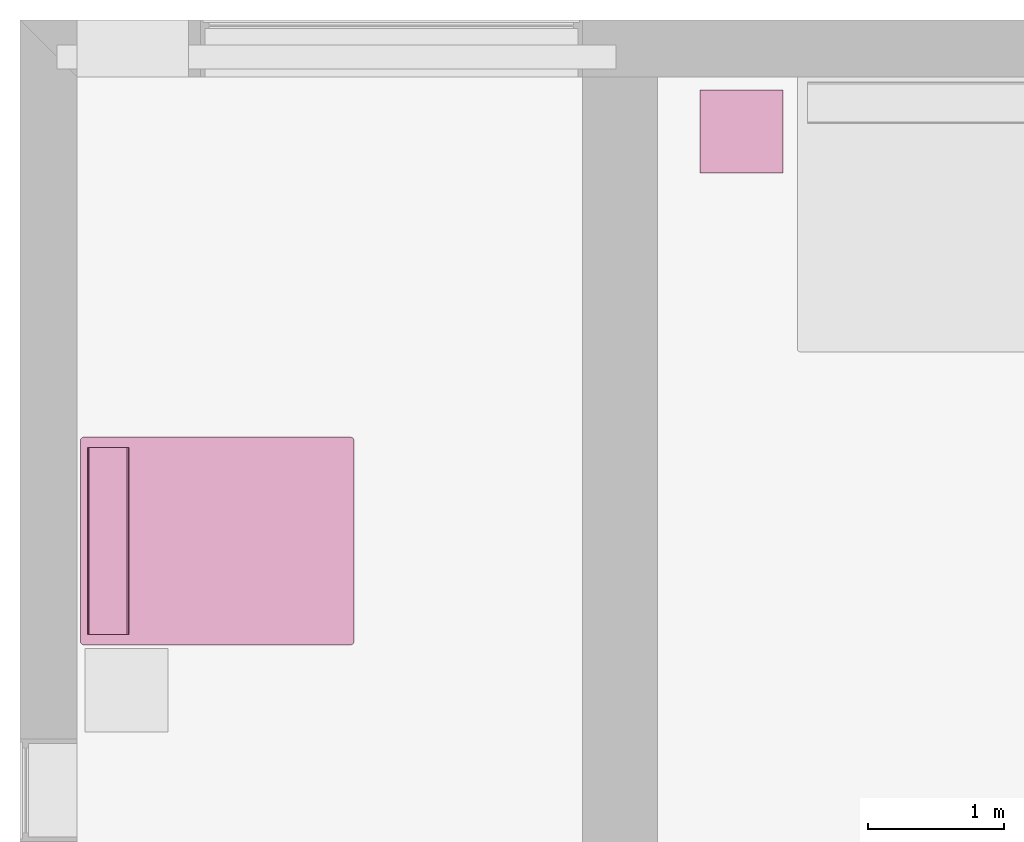
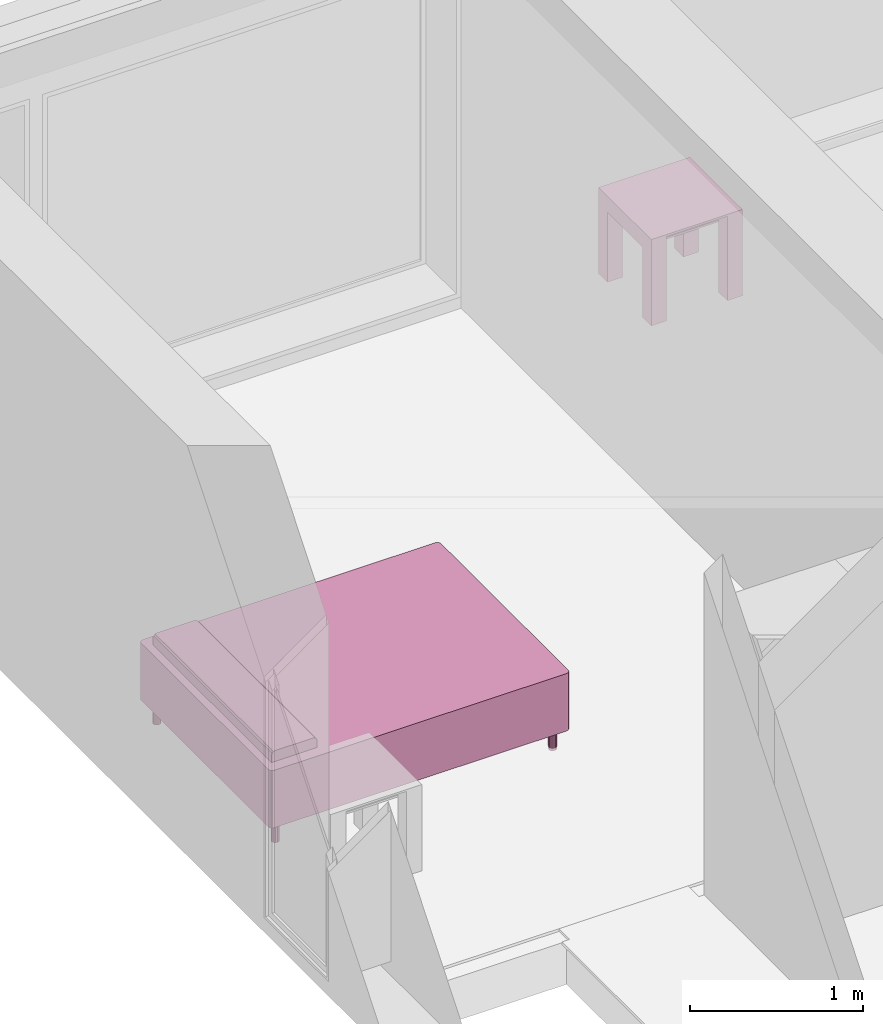
# One storey, part 9 of 12: 2 furnishings.
"""IFC2X3 building model written with IfcOpenShell, lengths in metres."""

from ifc_helpers import new_model, entity, si_unit, converted_unit, frame, origin, origin_2d_with_axis, place, context, project, spatial, polyline, rectangle, outline, extrude, face_set, surface_model, source, transform, mapped, type_object, type_shapes, element, save


model = new_model("IFC2X3")

# Units and contexts
model_context = context("Model", 3, precision=1e-09, world=origin())
plan_context = context("Plan", 3, precision=1e-09, world=origin())
ifc_project = project(units=[si_unit("LENGTHUNIT", "METRE"), si_unit("AREAUNIT", "SQUARE_METRE"), si_unit("VOLUMEUNIT", "CUBIC_METRE"), converted_unit("PLANEANGLEUNIT", "DEGREE", entity("IfcRatioMeasure", 0.0174532925199433), si_unit("PLANEANGLEUNIT", "RADIAN"), dimensions=[0, 0, 0, 0, 0, 0, 0]), si_unit("TIMEUNIT", "SECOND")], contexts=[model_context, plan_context])

# Site, building, storey, space
site_placement = place(None, origin())
site = spatial("IfcSite", under=ifc_project, at=site_placement, CompositionType="ELEMENT")
building_placement = place(site_placement, origin())
building = spatial("IfcBuilding", under=site, at=building_placement, CompositionType="ELEMENT")
storey_placement = place(building_placement, frame((0.0, 0.0, 3.10000000000038)))
storey = spatial("IfcBuildingStorey", under=building, at=storey_placement, Name="Level 2", CompositionType="ELEMENT", Elevation=3.10000000000038)
space_1_placement = place(storey_placement, origin())
space_1 = spatial("IfcSpace", under=storey, at=space_1_placement, CompositionType="ELEMENT", InteriorOrExteriorSpace="INTERNAL")

# Furnishing
furniture_type_1 = type_object("IfcFurnitureType", Name="0610 x 0610 x 0610mm", AssemblyPlace="NOTDEFINED")
shared_shape_1 = source(origin(), model_context, "Body", "SweptSolid", [
    extrude(rectangle(XDim=0.406799999999999, YDim=0.406799999999999, at=origin_2d_with_axis()), frame((0.0182657666726316, 0.0952110778022263, 0.4957), z_axis=(0.0, 0.0, 1.0), x_axis=(-1.0, 0.0, 0.0)), (0.0, 0.0, 1.0), 0.0127),
    extrude(outline(polyline([(-0.273249999999994, -0.305), (0.324049999999978, -0.305), (0.324049999999978, 0.304999999999998), (-0.273249999999993, 0.304999999999999), (-0.273249999999993, 0.203400000000001), (0.222450000000009, 0.203400000000001), (0.222450000000009, -0.2034), (-0.273249999999994, -0.2034), (-0.273249999999994, -0.305)])), frame((0.221665766672633, 0.0952110778022354, 0.273249999999992), z_axis=(1.0, 0.0, 0.0), x_axis=(0.0, 0.0, 1.0)), (0.0, 0.0, 1.0), 0.1016),
    extrude(outline(polyline([(-0.305000000000004, -0.324050000000025), (0.304999999999994, -0.324050000000025), (0.304999999999994, 0.273250000000011), (0.203400000000004, 0.273250000000011), (0.203400000000004, -0.222449999999996), (-0.203399999999995, -0.222449999999996), (-0.203399999999995, 0.273250000000011), (-0.305000000000004, 0.273250000000011), (-0.305000000000004, -0.324050000000025)])), frame((-0.286734233327367, 0.0952110778022256, 0.273250000000008), z_axis=(1.0, 0.0, 0.0), x_axis=(0.0, -1.0, 0.0)), (0.0, 0.0, 1.0), 0.1016),
    extrude(rectangle(XDim=0.406799999999999, YDim=0.406799999999999, at=origin_2d_with_axis()), frame((0.0182657666726316, 0.0952110778022259, 0.5973), z_axis=(0.0, 0.0, 1.0), x_axis=(-1.0, 0.0, 0.0)), (0.0, 0.0, 1.0), 0.0127),
    extrude(outline(polyline([(-0.305, -0.305000000000023), (0.305, -0.305000000000023), (0.305, 0.305000000000023), (-0.305, 0.305000000000023), (-0.305, -0.305000000000023)]), holes=[polyline([(-0.203399999999998, -0.203399999999975), (-0.203399999999998, 0.203400000000025), (0.203400000000001, 0.203400000000025), (0.203400000000001, -0.203399999999975), (-0.203399999999998, -0.203399999999975)])]), frame((0.0182657666726332, 0.0952110778022508, 0.5973), z_axis=(0.0, 0.0, 1.0), x_axis=(-1.0, 0.0, 0.0)), (0.0, 0.0, 1.0), 0.0127),
])
type_shapes(furniture_type_1, [shared_shape_1])
furnishing_1_placement = place(space_1_placement, frame((5.27573423332738, -0.91221107780225, 0.0189999999998181)))
element("IfcFurnishingElement", 1, at=furnishing_1_placement, inside=space_1, type_object=furniture_type_1, Name="M_Table-Coffee:0610 x 0610 x 0610mm:0610 x 0610 x 0610mm", ObjectType="0610 x 0610 x 0610mm", context=model_context, shape_type="MappedRepresentation", body=[
    mapped(shared_shape_1, transform((0.0, 0.0, 0.0), scale=1.0)),
])

# Space
space_2_placement = place(storey_placement, origin())
space_2 = spatial("IfcSpace", under=storey, at=space_2_placement, CompositionType="ELEMENT", InteriorOrExteriorSpace="INTERNAL")

# Furnishing
furniture_type_2 = type_object("IfcFurnitureType", Name="1525 x 2007mm - Queen", AssemblyPlace="NOTDEFINED")
shared_shape_2 = source(origin(), model_context, "Body", "SurfaceModel", [
    surface_model("IfcFaceBasedSurfaceModel", [(0.00159527223591624, 0.0269952722359165, 0.3556), (0.00159527223591617, 1.98319527223597, 0.3556), (0.00499822697978469, 1.99589527223594, 0.3556), (0.0142952722358907, 2.00519231749205, 0.3556), (0.0269952722358649, 2.00859527223592, 0.3556), (1.50119527223594, 2.00859527223592, 0.3556), (1.51389527223591, 2.00519231749205, 0.3556), (1.52319231749202, 1.99589527223594, 0.3556), (1.52659527223589, 1.98319527223596, 0.3556), (1.52659527223589, 0.0269952722358909, 0.3556), (1.52319231749202, 0.0142952722359035, 0.3556), (1.5138952722359, 0.00499822697978794, 0.3556), (1.50119527223591, 0.00159527223591603, 0.3556), (0.0269952722359164, 0.00159527223591603, 0.3556), (0.0142952722359163, 0.00499822697979146, 0.3556), (0.00499822697979146, 0.0142952722359164, 0.3556), (0.00159527223591624, 0.0269952722359162, 0.1524), (0.00159527223591617, 1.98319527223597, 0.1524), (0.00499822697978469, 1.99589527223594, 0.1524), (0.0142952722358907, 2.00519231749205, 0.1524), (0.0269952722358651, 2.00859527223592, 0.1524), (1.50119527223594, 2.00859527223592, 0.1524), (1.51389527223591, 2.00519231749205, 0.1524), (1.52319231749202, 1.99589527223594, 0.1524), (1.52659527223589, 1.98319527223596, 0.1524), (1.52659527223589, 0.0269952722358909, 0.1524), (1.52319231749202, 0.0142952722359035, 0.1524), (1.5138952722359, 0.00499822697978794, 0.1524), (1.50119527223591, 0.00159527223591617, 0.1524), (0.0269952722359163, 0.00159527223591603, 0.1524), (0.0142952722359163, 0.00499822697979146, 0.1524), (0.00499822697979146, 0.0142952722359164, 0.1524), (0.00355996331200004, 0.0196629520505667, 0.152400001883507), (0.00329675269313157, 0.0206453055143356, 0.355599999427795), (0.0096467649564147, 0.00964677613228559, 0.355599999427795), (0.0096467649564147, 0.00964677613228559, 0.152400001883507), (0.0206452570855617, 0.0032967277802527, 0.152400001883507), (0.0196629408746958, 0.00355993839912116, 0.355599999427795), (1.50852763652801, 0.00355993839912116, 0.152400001883507), (1.50754535198212, 0.0032967277802527, 0.355599999427795), (1.51854372024536, 0.00964677613228559, 0.355599999427795), (1.51854372024536, 0.00964677613228559, 0.152400001883507), (1.52489376068115, 0.0206453055143356, 0.152400001883507), (1.52463054656982, 0.0196629520505667, 0.355599999427795), (1.52489376068115, 1.98954522609711, 0.355599999427795), (1.52489376068115, 1.98954522609711, 0.152400001883507), (1.51854372024536, 2.00054383277893, 0.355599999427795), (1.51854372024536, 2.00054383277893, 0.152400001883507), (1.50754535198212, 2.00689387321472, 0.152400001883507), (1.50852763652801, 2.00663065910339, 0.355599999427795), (0.0196629408746958, 2.00663065910339, 0.152400001883507), (0.0206452570855617, 2.00689387321472, 0.355599999427795), (0.0096467649564147, 2.00054383277893, 0.355599999427795), (0.0096467649564147, 2.00054383277893, 0.152400001883507), (0.00329675269313157, 1.98954522609711, 0.152400001883507), (0.00355996331200004, 1.99052762985229, 0.355599999427795), (0.0777952722359187, 1.65299527223593, 0.5588), (0.0777952722359187, 1.65299527223593, 0.6096), (0.0777952722359187, 1.65639822697981, 0.6223), (0.0777952722359187, 1.66569527223593, 0.631597045256125), (0.0777952722359188, 1.67839527223593, 0.635), (0.0777952722359192, 1.93239527223593, 0.635), (0.0777952722359193, 1.94509527223593, 0.631597045256125), (0.0777952722359193, 1.95439231749205, 0.6223), (0.0777952722359193, 1.95779527223593, 0.6096), (0.0777952722359193, 1.95779527223593, 0.5588), (1.45039527223589, 1.65299527223593, 0.5588), (1.45039527223589, 1.95779527223593, 0.5588), (1.45039527223589, 1.95779527223593, 0.6096), (1.45039527223589, 1.95439231749205, 0.6223), (1.45039527223589, 1.94509527223593, 0.631597045256125), (1.45039527223589, 1.93239527223593, 0.635), (1.45039527223589, 1.67839527223593, 0.635), (1.45039527223589, 1.66569527223593, 0.631597045256125), (1.45039527223589, 1.6563982269798, 0.6223), (1.45039527223589, 1.65299527223593, 0.6096), (0.0777952596545219, 1.65532207489014, 0.618283867835999), (1.45039534568787, 1.65469682216644, 0.615949988365173), (0.0777952596545219, 1.65415871143341, 0.613941967487335), (0.0777952596545219, 1.67405331134796, 0.633836627006531), (1.45039534568787, 1.67204535007477, 0.633298575878143), (0.0777952596545219, 1.66104674339294, 0.626948475837708), (1.45039534568787, 1.66104674339294, 0.626948475837708), (0.0777952596545219, 1.66971147060394, 0.632673144340515), (1.45039534568787, 1.94107913970947, 0.632673144340515), (0.0777952596545219, 1.95663189888001, 0.613941967487335), (1.45039534568787, 1.95609378814697, 0.615949988365173), (0.0777952596545219, 1.93874526023865, 0.633298575878143), (1.45039534568787, 1.93673717975616, 0.633836627006531), (0.0777952596545219, 1.94974374771118, 0.626948475837708), (1.45039534568787, 1.94974374771118, 0.626948475837708), (0.0777952596545219, 1.95546841621399, 0.618283867835999), (0.103195272235893, 1.93239527223591, 0.1524), (0.100679881480615, 1.92137462526233, 0.1524), (0.0936319132031052, 1.91253675258122, 0.1524), (0.0834473039583838, 1.90763210326649, 0.1524), (0.0721432405134031, 1.90763210326649, 0.1524), (0.0619586312686816, 1.91253675258122, 0.1524), (0.054910662991172, 1.92137462526233, 0.1524), (0.0523952722358935, 1.93239527223591, 0.1524), (0.054910662991172, 1.9434159192095, 0.1524), (0.0619586312686816, 1.9522537918906, 0.1524), (0.072143240513403, 1.95715844120533, 0.1524), (0.0834473039583837, 1.95715844120533, 0.1524), (0.093631913203105, 1.9522537918906, 0.1524), (0.100679881480615, 1.9434159192095, 0.1524), (1.47579527223591, 1.93239527223594, 0.1524), (1.47327988148063, 1.92137462526234, 0.1524), (1.46623191320311, 1.91253675258123, 0.1524), (1.45604730395838, 1.9076321032665, 0.1524), (1.44474324051339, 1.9076321032665, 0.1524), (1.43455863126866, 1.91253675258123, 0.1524), (1.42751066299114, 1.92137462526234, 0.1524), (1.42499527223586, 1.93239527223594, 0.1524), (1.42751066299114, 1.94341591920954, 0.1524), (1.43455863126866, 1.95225379189065, 0.1524), (1.44474324051339, 1.95715844120538, 0.1524), (1.45604730395838, 1.95715844120538, 0.1524), (1.46623191320311, 1.95225379189065, 0.1524), (1.47327988148063, 1.94341591920954, 0.1524), (1.47579527223591, 0.0777952722359423, 0.1524), (1.47327988148063, 0.0667746252623562, 0.1524), (1.46623191320312, 0.0579367525812542, 0.1524), (1.4560473039584, 0.0530321032665241, 0.1524), (1.44474324051342, 0.0530321032665238, 0.1524), (1.4345586312687, 0.0579367525812542, 0.1524), (1.42751066299119, 0.0667746252623562, 0.1524), (1.42499527223591, 0.077795272235942, 0.1524), (1.42751066299119, 0.0888159192095284, 0.1524), (1.4345586312687, 0.0976537918906301, 0.1524), (1.44474324051342, 0.102558441205361, 0.1524), (1.4560473039584, 0.102558441205361, 0.1524), (1.46623191320312, 0.0976537918906301, 0.1524), (1.47327988148063, 0.0888159192095281, 0.1524), (0.103195272235918, 0.0777952722359125, 0.1524), (0.10067988148064, 0.0667746252623251, 0.1524), (0.0936319132031292, 0.0579367525812217, 0.1524), (0.0834473039584065, 0.0530321032664908, 0.1524), (0.0721432405134241, 0.0530321032664908, 0.1524), (0.0619586312687013, 0.0579367525812217, 0.1524), (0.0549106629911907, 0.0667746252623248, 0.1524), (0.0523952722359118, 0.0777952722359122, 0.1524), (0.0549106629911907, 0.0888159192094999, 0.1524), (0.0619586312687013, 0.0976537918906031, 0.1524), (0.0721432405134241, 0.102558441205334, 0.1524), (0.0834473039584063, 0.102558441205334, 0.1524), (0.0936319132031291, 0.0976537918906028, 0.1524), (0.10067988148064, 0.0888159192094997, 0.1524), (0.103195272235893, 1.93239527223591, 0.0), (0.100679881480615, 1.92137462526233, 0.0), (0.0936319132031052, 1.91253675258122, 0.0), (0.0834473039583838, 1.90763210326649, 0.0), (0.0721432405134031, 1.90763210326649, 0.0), (0.0619586312686816, 1.91253675258122, 0.0), (0.054910662991172, 1.92137462526233, 0.0), (0.0523952722358935, 1.93239527223591, 0.0), (0.054910662991172, 1.9434159192095, 0.0), (0.0619586312686816, 1.9522537918906, 0.0), (0.072143240513403, 1.95715844120533, 0.0), (0.0834473039583837, 1.95715844120533, 0.0), (0.093631913203105, 1.9522537918906, 0.0), (0.100679881480615, 1.9434159192095, 0.0), (1.47579527223591, 1.93239527223594, 0.0), (1.47327988148063, 1.92137462526234, 0.0), (1.46623191320311, 1.91253675258123, 0.0), (1.45604730395838, 1.9076321032665, 0.0), (1.44474324051339, 1.9076321032665, 0.0), (1.43455863126866, 1.91253675258123, 0.0), (1.42751066299114, 1.92137462526234, 0.0), (1.42499527223586, 1.93239527223594, 0.0), (1.42751066299114, 1.94341591920954, 0.0), (1.43455863126866, 1.95225379189065, 0.0), (1.44474324051339, 1.95715844120538, 0.0), (1.45604730395838, 1.95715844120538, 0.0), (1.46623191320311, 1.95225379189065, 0.0), (1.47327988148063, 1.94341591920954, 0.0), (1.47579527223591, 0.0777952722359423, 0.0), (1.47327988148063, 0.0667746252623562, 0.0), (1.46623191320312, 0.0579367525812542, 0.0), (1.4560473039584, 0.0530321032665241, 0.0), (1.44474324051342, 0.0530321032665238, 0.0), (1.4345586312687, 0.0579367525812542, 0.0), (1.42751066299119, 0.0667746252623562, 0.0), (1.42499527223591, 0.0777952722359423, 0.0), (1.42751066299119, 0.0888159192095284, 0.0), (1.4345586312687, 0.0976537918906301, 0.0), (1.44474324051342, 0.102558441205361, 0.0), (1.4560473039584, 0.102558441205361, 0.0), (1.46623191320312, 0.0976537918906301, 0.0), (1.47327988148063, 0.0888159192095281, 0.0), (0.103195272235919, 0.0777952722359125, 0.0), (0.10067988148064, 0.0667746252623251, 0.0), (0.0936319132031292, 0.0579367525812217, 0.0), (0.0834473039584065, 0.0530321032664908, 0.0), (0.0721432405134241, 0.0530321032664908, 0.0), (0.0619586312687013, 0.0579367525812217, 0.0), (0.0549106629911907, 0.0667746252623248, 0.0), (0.0523952722359117, 0.0777952722359125, 0.0), (0.0549106629911907, 0.0888159192094999, 0.0), (0.0619586312687013, 0.0976537918906031, 0.0), (0.0721432405134241, 0.102558441205334, 0.0), (0.0834473039584063, 0.102558441205334, 0.0), (0.0936319132031291, 0.0976537918906028, 0.0), (0.10067988148064, 0.0888159192094997, 0.0), (0.0536529831588268, 1.92688500881195, 0.152400001883507), (0.0584346316754818, 1.9169557094574, 0.0), (0.0584346316754818, 1.9169557094574, 0.152400001883507), (0.102065727114677, 1.92744648456574, 0.152400001883507), (0.10193756967783, 1.92688500881195, 0.0), (0.06705092638731, 1.9100843667984, 0.0), (0.06705092638731, 1.9100843667984, 0.152400001883507), (0.0535247921943665, 1.92744648456574, 0.0), (0.0777952596545219, 1.90763211250305, 0.152400001883507), (0.0777952596545219, 1.90763211250305, 0.0), (0.0885396227240562, 1.9100843667984, 0.0), (0.0885396227240562, 1.9100843667984, 0.152400001883507), (0.0971558839082718, 1.9169557094574, 0.152400001883507), (0.0971558839082718, 1.9169557094574, 0.0), (0.102065727114677, 1.93734407424927, 0.0), (0.10193756967783, 1.93790555000305, 0.152400001883507), (0.0971558839082718, 1.9478348493576, 0.0), (0.0971558839082718, 1.9478348493576, 0.152400001883507), (0.0885396227240562, 1.95470607280731, 0.152400001883507), (0.0885396227240562, 1.95470607280731, 0.0), (0.0777952596545219, 1.95715844631195, 0.152400001883507), (0.0777952596545219, 1.95715844631195, 0.0), (0.06705092638731, 1.95470607280731, 0.152400001883507), (0.06705092638731, 1.95470607280731, 0.0), (0.0535247921943665, 1.93734407424927, 0.152400001883507), (0.0584346316754818, 1.9478348493576, 0.152400001883507), (0.0584346316754818, 1.9478348493576, 0.0), (0.0536529831588268, 1.93790555000305, 0.0), (1.42625296115875, 1.92688500881195, 0.152400001883507), (1.43103468418121, 1.9169557094574, 0.0), (1.43103468418121, 1.9169557094574, 0.152400001883507), (1.47453761100769, 1.92688500881195, 0.0), (1.47466564178467, 1.92744648456574, 0.152400001883507), (1.43965089321136, 1.9100843667984, 0.0), (1.43965089321136, 1.9100843667984, 0.152400001883507), (1.42612481117248, 1.92744648456574, 0.0), (1.45039534568787, 1.90763211250305, 0.152400001883507), (1.45039534568787, 1.90763211250305, 0.0), (1.46113967895508, 1.9100843667984, 0.0), (1.46113967895508, 1.9100843667984, 0.152400001883507), (1.46975588798523, 1.9169557094574, 0.152400001883507), (1.46975588798523, 1.9169557094574, 0.0), (1.47466564178467, 1.93734407424927, 0.0), (1.47453761100769, 1.93790555000305, 0.152400001883507), (1.46975588798523, 1.9478348493576, 0.0), (1.46975588798523, 1.9478348493576, 0.152400001883507), (1.46113967895508, 1.95470607280731, 0.152400001883507), (1.46113967895508, 1.95470607280731, 0.0), (1.45039534568787, 1.95715844631195, 0.152400001883507), (1.45039534568787, 1.95715844631195, 0.0), (1.43965089321136, 1.95470607280731, 0.152400001883507), (1.43965089321136, 1.95470607280731, 0.0), (1.42612481117248, 1.93734407424927, 0.152400001883507), (1.43103468418121, 1.9478348493576, 0.152400001883507), (1.43103468418121, 1.9478348493576, 0.0), (1.42625296115875, 1.93790555000305, 0.0), (1.42625296115875, 0.072284959256649, 0.152400001883507), (1.43103468418121, 0.0623556971549988, 0.0), (1.43103468418121, 0.0623556971549988, 0.152400001883507), (1.47453761100769, 0.072284959256649, 0.0), (1.47466564178467, 0.0728464797139168, 0.152400001883507), (1.43965089321136, 0.0554844588041305, 0.152400001883507), (1.43965089321136, 0.0554844588041305, 0.0), (1.42612481117248, 0.0728464797139168, 0.0), (1.45039534568787, 0.0530321374535561, 0.0), (1.45039534568787, 0.0530321374535561, 0.152400001883507), (1.46113967895508, 0.0554844588041305, 0.152400001883507), (1.46113967895508, 0.0554844588041305, 0.0), (1.46975588798523, 0.0623556971549988, 0.152400001883507), (1.46975588798523, 0.0623556971549988, 0.0), (1.47466564178467, 0.0827441290020943, 0.0), (1.47453761100769, 0.0833055824041367, 0.152400001883507), (1.46975588798523, 0.0932348445057869, 0.152400001883507), (1.46975588798523, 0.0932348445057869, 0.0), (1.46113967895508, 0.100106082856655, 0.0), (1.46113967895508, 0.100106082856655, 0.152400001883507), (1.45039534568787, 0.102558471262455, 0.0), (1.45039534568787, 0.102558471262455, 0.152400001883507), (1.43965089321136, 0.100106082856655, 0.0), (1.43965089321136, 0.100106082856655, 0.152400001883507), (1.42612481117248, 0.0827441290020943, 0.152400001883507), (1.43103468418121, 0.0932348445057869, 0.0), (1.43103468418121, 0.0932348445057869, 0.152400001883507), (1.42625296115875, 0.0833055824041367, 0.0), (0.0536529831588268, 0.072284959256649, 0.152400001883507), (0.0584346316754818, 0.0623556971549988, 0.152400001883507), (0.0584346316754818, 0.0623556971549988, 0.0), (0.102065727114677, 0.0728464797139168, 0.152400001883507), (0.10193756967783, 0.072284959256649, 0.0), (0.06705092638731, 0.0554844588041305, 0.152400001883507), (0.06705092638731, 0.0554844588041305, 0.0), (0.0535247921943665, 0.0728464797139168, 0.0), (0.0777952596545219, 0.0530321374535561, 0.0), (0.0777952596545219, 0.0530321374535561, 0.152400001883507), (0.0885396227240562, 0.0554844588041305, 0.152400001883507), (0.0885396227240562, 0.0554844588041305, 0.0), (0.0971558839082718, 0.0623556971549988, 0.152400001883507), (0.0971558839082718, 0.0623556971549988, 0.0), (0.102065727114677, 0.0827441290020943, 0.0), (0.10193756967783, 0.0833055824041367, 0.152400001883507), (0.0971558839082718, 0.0932348445057869, 0.152400001883507), (0.0971558839082718, 0.0932348445057869, 0.0), (0.0885396227240562, 0.100106082856655, 0.0), (0.0885396227240562, 0.100106082856655, 0.152400001883507), (0.0777952596545219, 0.102558471262455, 0.0), (0.0777952596545219, 0.102558471262455, 0.152400001883507), (0.06705092638731, 0.100106082856655, 0.0), (0.06705092638731, 0.100106082856655, 0.152400001883507), (0.0535247921943665, 0.0827441290020943, 0.152400001883507), (0.0584346316754818, 0.0932348445057869, 0.0), (0.0584346316754818, 0.0932348445057869, 0.152400001883507), (0.0536529831588268, 0.0833055824041367, 0.0), (0.0269952722358657, 2.00859527223592, 0.5588), (1.50119527223594, 2.00859527223592, 0.5588), (1.51389527223591, 2.00519231749205, 0.5588), (1.52319231749202, 1.99589527223594, 0.5588), (1.52659527223589, 1.98319527223597, 0.5588), (1.52659527223589, 0.0269952722358909, 0.5588), (1.52319231749202, 0.0142952722359035, 0.5588), (1.5138952722359, 0.00499822697978794, 0.5588), (1.50119527223591, 0.00159527223591617, 0.5588), (0.0269952722359165, 0.00159527223591617, 0.5588), (0.0142952722359161, 0.00499822697979173, 0.5588), (0.00499822697979126, 0.0142952722359165, 0.5588), (0.00159527223591597, 0.0269952722359169, 0.5588), (0.00159527223591597, 1.98319527223597, 0.5588), (0.00499822697978462, 1.99589527223594, 0.5588), (0.014295272235891, 2.00519231749205, 0.5588), (0.0269952722358655, 2.00859527223592, 0.3556), (1.50119527223594, 2.00859527223592, 0.3556), (1.51389527223591, 2.00519231749205, 0.3556), (1.52319231749202, 1.99589527223594, 0.3556), (1.52659527223589, 1.98319527223597, 0.3556), (1.52659527223589, 0.0269952722358909, 0.3556), (1.52319231749202, 0.0142952722359035, 0.3556), (1.5138952722359, 0.00499822697978794, 0.3556), (1.50119527223591, 0.00159527223591617, 0.3556), (0.0269952722359166, 0.00159527223591617, 0.3556), (0.0142952722359161, 0.00499822697979173, 0.3556), (0.00499822697979126, 0.0142952722359165, 0.3556), (0.00159527223591597, 0.0269952722359169, 0.3556), (0.00159527223591597, 1.98319527223597, 0.3556), (0.00499822697978462, 1.99589527223594, 0.3556), (0.014295272235891, 2.00519231749205, 0.3556), (0.0196629408746958, 2.00663065910339, 0.355599999427795), (0.0206452570855617, 2.00689387321472, 0.558800041675568), (0.0096467649564147, 2.00054383277893, 0.558800041675568), (0.0096467649564147, 2.00054383277893, 0.355599999427795), (0.00329675269313157, 1.98954522609711, 0.355599999427795), (0.00355996331200004, 1.99052762985229, 0.558800041675568), (0.00355996331200004, 0.0196629520505667, 0.355599999427795), (0.00329675269313157, 0.0206453055143356, 0.558800041675568), (0.0096467649564147, 0.00964677613228559, 0.558800041675568), (0.0096467649564147, 0.00964677613228559, 0.355599999427795), (0.0206452570855617, 0.0032967277802527, 0.355599999427795), (0.0196629408746958, 0.00355993839912116, 0.558800041675568), (1.50852763652801, 0.00355993839912116, 0.355599999427795), (1.50754535198212, 0.0032967277802527, 0.558800041675568), (1.51854372024536, 0.00964677613228559, 0.558800041675568), (1.51854372024536, 0.00964677613228559, 0.355599999427795), (1.52489376068115, 0.0206453055143356, 0.355599999427795), (1.52463054656982, 0.0196629520505667, 0.558800041675568), (1.52463054656982, 1.99052762985229, 0.355599999427795), (1.52489376068115, 1.98954522609711, 0.558800041675568), (1.51854372024536, 2.00054383277893, 0.558800041675568), (1.51854372024536, 2.00054383277893, 0.355599999427795), (1.50754535198212, 2.00689387321472, 0.355599999427795), (1.50852763652801, 2.00663065910339, 0.558800041675568)], [face_set([[[0, 1, 2, 3, 4, 5, 6, 7, 8, 9, 10, 11, 12, 13, 14, 15]], [[16, 17, 18, 19, 20, 21, 22, 23, 24, 25, 26, 27, 28, 29, 30, 31]], [[15, 32, 31]], [[32, 15, 33]], [[33, 0, 16]], [[34, 35, 30, 14]], [[16, 32, 33]], [[36, 29, 13]], [[37, 30, 36]], [[35, 34, 15, 31]], [[30, 37, 14]], [[13, 37, 36]], [[12, 28, 29, 13]], [[11, 38, 27]], [[38, 11, 39]], [[39, 12, 28]], [[40, 41, 26, 10]], [[28, 38, 39]], [[42, 25, 9]], [[43, 26, 42]], [[41, 40, 11, 27]], [[26, 43, 10]], [[9, 43, 42]], [[8, 9, 25, 24]], [[44, 8, 24, 45]], [[44, 45, 23, 7]], [[46, 47, 22, 6]], [[48, 21, 5]], [[5, 49, 48]], [[22, 49, 6]], [[47, 46, 7, 23]], [[49, 22, 48]], [[4, 5, 21, 20]], [[3, 50, 19]], [[50, 3, 51]], [[51, 4, 20]], [[52, 53, 18, 2]], [[20, 50, 51]], [[54, 17, 1]], [[55, 18, 54]], [[53, 52, 3, 19]], [[18, 55, 2]], [[1, 55, 54]], [[0, 1, 17, 16]]]), face_set([[[56, 57, 58, 59, 60, 61, 62, 63, 64, 65]], [[66, 67, 68, 69, 70, 71, 72, 73, 74, 75]], [[57, 56, 66, 75]], [[74, 76, 77]], [[78, 75, 77]], [[72, 79, 80]], [[77, 76, 78]], [[81, 82, 73, 59]], [[78, 57, 75]], [[60, 79, 72]], [[83, 80, 79]], [[73, 83, 59]], [[82, 81, 58, 74]], [[83, 73, 80]], [[74, 58, 76]], [[61, 71, 72, 60]], [[62, 84, 70]], [[68, 85, 86]], [[84, 62, 87]], [[71, 88, 61]], [[89, 90, 69, 63]], [[84, 87, 88]], [[64, 85, 68]], [[91, 69, 86]], [[90, 89, 62, 70]], [[69, 91, 63]], [[91, 86, 85]], [[61, 88, 87]], [[65, 67, 68, 64]], [[56, 65, 67, 66]]]), face_set([[[92, 93, 94, 95, 96, 97, 98, 99, 100, 101, 102, 103, 104, 105]], [[106, 107, 108, 109, 110, 111, 112, 113, 114, 115, 116, 117, 118, 119]], [[120, 121, 122, 123, 124, 125, 126, 127, 128, 129, 130, 131, 132, 133]], [[134, 135, 136, 137, 138, 139, 140, 141, 142, 143, 144, 145, 146, 147]], [[148, 149, 150, 151, 152, 153, 154, 155, 156, 157, 158, 159, 160, 161]], [[162, 163, 164, 165, 166, 167, 168, 169, 170, 171, 172, 173, 174, 175]], [[176, 177, 178, 179, 180, 181, 182, 183, 184, 185, 186, 187, 188, 189]], [[190, 191, 192, 193, 194, 195, 196, 197, 198, 199, 200, 201, 202, 203]], [[98, 204, 154]], [[97, 153, 205, 206]], [[207, 208, 93]], [[96, 152, 209, 210]], [[154, 204, 211]], [[204, 99, 211]], [[154, 98, 206, 205]], [[210, 209, 153, 97]], [[96, 212, 151, 213]], [[99, 155, 211]], [[94, 150, 214, 215]], [[150, 94, 216, 217]], [[93, 149, 217, 216]], [[151, 95, 215, 214]], [[208, 207, 148]], [[93, 208, 149]], [[212, 95, 151]], [[96, 213, 152]], [[207, 92, 148]], [[218, 148, 92]], [[219, 218, 92]], [[220, 160, 221, 105]], [[222, 223, 159, 103]], [[218, 219, 161]], [[161, 219, 105]], [[160, 104, 221]], [[220, 105, 161]], [[104, 160, 223, 222]], [[224, 225, 158, 102]], [[226, 227, 157, 101]], [[155, 99, 228]], [[229, 230, 156, 100]], [[230, 229, 101, 157]], [[155, 228, 231]], [[102, 158, 227, 226]], [[156, 231, 100]], [[225, 224, 103, 159]], [[100, 231, 228]], [[168, 232, 112]], [[111, 167, 233, 234]], [[107, 235, 236]], [[110, 166, 237, 238]], [[239, 232, 168]], [[239, 113, 232]], [[168, 112, 234, 233]], [[238, 237, 167, 111]], [[110, 240, 165, 241]], [[239, 169, 113]], [[108, 164, 242, 243]], [[164, 108, 244, 245]], [[107, 163, 245, 244]], [[165, 109, 243, 242]], [[162, 236, 235]], [[163, 235, 107]], [[240, 109, 165]], [[110, 241, 166]], [[162, 106, 236]], [[106, 162, 246]], [[106, 246, 247]], [[248, 174, 249, 119]], [[250, 251, 173, 117]], [[175, 247, 246]], [[119, 247, 175]], [[174, 118, 249]], [[248, 119, 175]], [[118, 174, 251, 250]], [[252, 253, 172, 116]], [[254, 255, 171, 115]], [[256, 113, 169]], [[257, 258, 170, 114]], [[258, 257, 115, 171]], [[259, 256, 169]], [[116, 172, 255, 254]], [[114, 259, 170]], [[253, 252, 117, 173]], [[256, 259, 114]], [[182, 260, 126]], [[261, 181, 262, 126]], [[121, 263, 264]], [[265, 266, 180, 124]], [[267, 260, 182]], [[267, 127, 260]], [[126, 182, 261]], [[125, 181, 266, 265]], [[181, 125, 262]], [[268, 179, 269, 124]], [[267, 183, 127]], [[270, 271, 178, 122]], [[272, 122, 273, 177]], [[271, 270, 123, 179]], [[177, 121, 272]], [[176, 264, 263]], [[122, 178, 273]], [[177, 263, 121]], [[179, 123, 269]], [[180, 268, 124]], [[176, 120, 264]], [[120, 176, 274]], [[120, 274, 275]], [[133, 276, 188, 277]], [[131, 187, 278, 279]], [[189, 275, 274]], [[133, 275, 189]], [[276, 132, 188]], [[189, 133, 277]], [[279, 278, 188, 132]], [[130, 186, 280, 281]], [[129, 185, 282, 283]], [[284, 127, 183]], [[128, 184, 285, 286]], [[185, 129, 286, 285]], [[287, 284, 183]], [[283, 282, 186, 130]], [[128, 287, 184]], [[187, 131, 281, 280]], [[284, 287, 128]], [[140, 288, 196]], [[289, 290, 195, 139]], [[291, 292, 135]], [[293, 294, 194, 138]], [[196, 288, 295]], [[288, 141, 295]], [[290, 289, 140, 196]], [[139, 195, 294, 293]], [[296, 193, 297, 138]], [[141, 197, 295]], [[298, 299, 192, 136]], [[300, 136, 301, 191]], [[299, 298, 137, 193]], [[191, 135, 300]], [[292, 291, 190]], [[136, 192, 301]], [[135, 292, 191]], [[193, 137, 297]], [[194, 296, 138]], [[291, 134, 190]], [[302, 190, 134]], [[303, 302, 134]], [[147, 304, 202, 305]], [[145, 201, 306, 307]], [[302, 303, 203]], [[203, 303, 147]], [[304, 146, 202]], [[203, 147, 305]], [[307, 306, 202, 146]], [[144, 200, 308, 309]], [[143, 199, 310, 311]], [[197, 141, 312]], [[142, 198, 313, 314]], [[199, 143, 314, 313]], [[197, 312, 315]], [[311, 310, 200, 144]], [[198, 315, 142]], [[201, 145, 309, 308]], [[142, 315, 312]]]), face_set([[[316, 317, 318, 319, 320, 321, 322, 323, 324, 325, 326, 327, 328, 329, 330, 331]], [[332, 333, 334, 335, 336, 337, 338, 339, 340, 341, 342, 343, 344, 345, 346, 347]], [[331, 348, 347]], [[348, 331, 349]], [[349, 316, 332]], [[350, 351, 346, 330]], [[332, 348, 349]], [[352, 345, 329]], [[353, 346, 352]], [[351, 350, 331, 347]], [[346, 353, 330]], [[329, 353, 352]], [[328, 329, 345, 344]], [[327, 354, 343]], [[354, 327, 355]], [[355, 328, 344]], [[356, 357, 342, 326]], [[344, 354, 355]], [[358, 341, 325]], [[359, 342, 358]], [[357, 356, 327, 343]], [[342, 359, 326]], [[325, 359, 358]], [[324, 340, 341, 325]], [[323, 360, 339]], [[360, 323, 361]], [[361, 324, 340]], [[362, 363, 338, 322]], [[340, 360, 361]], [[364, 337, 321]], [[365, 338, 364]], [[363, 362, 323, 339]], [[338, 365, 322]], [[321, 365, 364]], [[320, 321, 337, 336]], [[319, 366, 335]], [[366, 319, 367]], [[367, 320, 336]], [[368, 369, 334, 318]], [[336, 366, 367]], [[370, 333, 317]], [[371, 334, 370]], [[369, 368, 319, 335]], [[334, 371, 318]], [[317, 371, 370]], [[316, 317, 333, 332]]])]),
])
type_shapes(furniture_type_2, [shared_shape_2])
furnishing_2_placement = place(space_2_placement, frame((2.45159527223592, -4.58609527223591, 0.0), z_axis=(0.0, 0.0, 1.0), x_axis=(0.0, 1.0, 0.0)))
element("IfcFurnishingElement", 2, at=furnishing_2_placement, inside=space_2, type_object=furniture_type_2, Name="M_Bed-Standard:1525 x 2007mm - Queen:1525 x 2007mm - Queen", ObjectType="1525 x 2007mm - Queen", context=model_context, shape_type="MappedRepresentation", body=[
    mapped(shared_shape_2, transform((0.0, 0.0, 0.0), scale=1.0)),
])

save(model, "model.ifc")
